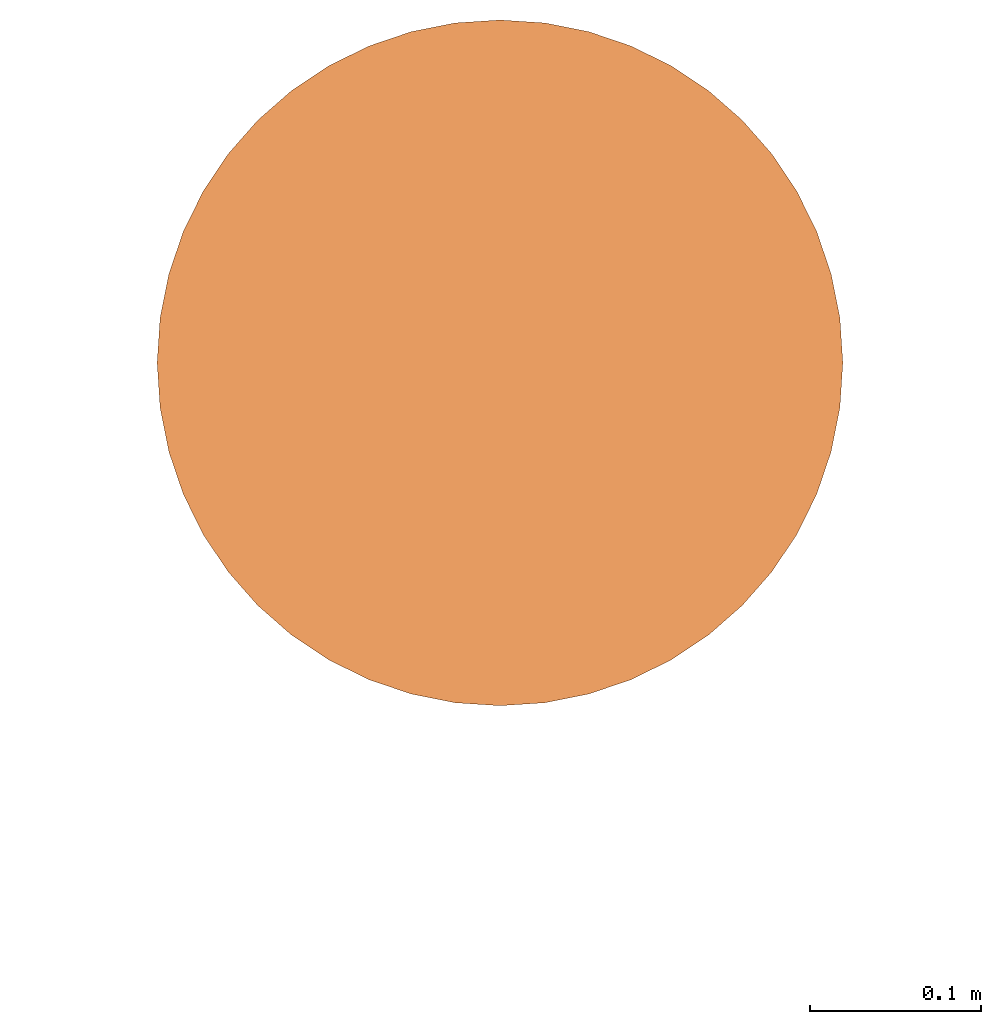
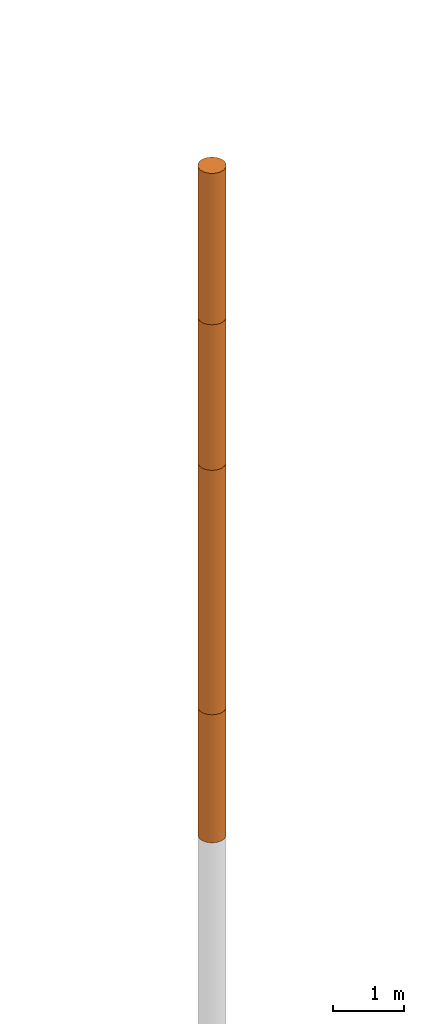
# Not in any storey, part 3 of 5: 4 geographic elements.
"""IFC4 model written with IfcOpenShell, lengths in metres."""

from ifc_helpers import new_model, entity, si_unit, converted_unit, frame, frame_2d, origin_with_axes, place, context, subcontext, project, spatial, polygons, element, save


model = new_model("IFC4")

# Units and contexts
model_context = context("Model", 3, precision=1e-05, world=origin_with_axes())
plan_context = context("Plan", 2, precision=1e-05, world=frame_2d((0.0, 0.0, 0.0), x_axis=(1.0, 0.0, 0.0)))
body_context = subcontext(model_context, "Body", "Model", "MODEL_VIEW")
ifc_project = project(units=[si_unit("VOLUMEUNIT", "CUBIC_METRE"), si_unit("LENGTHUNIT", "METRE"), converted_unit("PLANEANGLEUNIT", "degree", entity("IfcReal", 0.0174532925199433), si_unit("PLANEANGLEUNIT", "RADIAN"), dimensions=[0, 0, 0, 0, 0, 0, 0]), si_unit("AREAUNIT", "SQUARE_METRE")], contexts=[model_context, plan_context])

# Site
site_placement = place(None, origin_with_axes())
site = spatial("IfcSite", under=ifc_project, at=site_placement)

# Geographic elements
geographic_element_1_placement = place(site_placement, frame((19.3999996185303, 90.9000015258789, 17.6000003814697), z_axis=(0.0, 0.0, 1.0), x_axis=(1.0, 0.0, 0.0)))
element("IfcGeographicElement", 1, at=geographic_element_1_placement, inside=site, Name="BH_1_L_1", PredefinedType="NOTDEFINED", context=body_context, shape_type="Tessellation", body=[
    polygons([(0.0, 0.200000002980232, -1.29999995231628), (0.0, 0.200000002980232, 1.29999995231628), (0.0261052399873734, 0.198288977146149, -1.29999995231628), (0.0261052399873734, 0.198288977146149, 1.29999995231628), (0.0517638102173805, 0.193185165524483, -1.29999995231628), (0.0517638102173805, 0.193185165524483, 1.29999995231628), (0.0765366926789284, 0.184775903820992, -1.29999995231628), (0.0765366926789284, 0.184775903820992, 1.29999995231628), (0.100000001490116, 0.173205077648163, -1.29999995231628), (0.100000001490116, 0.173205077648163, 1.29999995231628), (0.12175228446722, 0.158670663833618, -1.29999995231628), (0.12175228446722, 0.158670663833618, 1.29999995231628), (0.141421362757683, 0.141421362757683, -1.29999995231628), (0.141421362757683, 0.141421362757683, 1.29999995231628), (0.158670663833618, 0.12175228446722, -1.29999995231628), (0.158670663833618, 0.12175228446722, 1.29999995231628), (0.173205077648163, 0.100000001490116, -1.29999995231628), (0.173205077648163, 0.100000001490116, 1.29999995231628), (0.184775903820992, 0.0765366926789284, -1.29999995231628), (0.184775903820992, 0.0765366926789284, 1.29999995231628), (0.193185165524483, 0.0517638102173805, -1.29999995231628), (0.193185165524483, 0.0517638102173805, 1.29999995231628), (0.198288977146149, 0.0261052399873734, -1.29999995231628), (0.198288977146149, 0.0261052399873734, 1.29999995231628), (0.200000002980232, 0.0, -1.29999995231628), (0.200000002980232, 0.0, 1.29999995231628), (0.198288977146149, -0.0261052399873734, -1.29999995231628), (0.198288977146149, -0.0261052399873734, 1.29999995231628), (0.193185165524483, -0.0517638102173805, -1.29999995231628), (0.193185165524483, -0.0517638102173805, 1.29999995231628), (0.184775903820992, -0.0765366926789284, -1.29999995231628), (0.184775903820992, -0.0765366926789284, 1.29999995231628), (0.173205077648163, -0.100000001490116, -1.29999995231628), (0.173205077648163, -0.100000001490116, 1.29999995231628), (0.158670663833618, -0.12175228446722, -1.29999995231628), (0.158670663833618, -0.12175228446722, 1.29999995231628), (0.141421362757683, -0.141421362757683, -1.29999995231628), (0.141421362757683, -0.141421362757683, 1.29999995231628), (0.12175228446722, -0.158670663833618, -1.29999995231628), (0.12175228446722, -0.158670663833618, 1.29999995231628), (0.100000001490116, -0.173205077648163, -1.29999995231628), (0.100000001490116, -0.173205077648163, 1.29999995231628), (0.0765366926789284, -0.184775903820992, -1.29999995231628), (0.0765366926789284, -0.184775903820992, 1.29999995231628), (0.0517638102173805, -0.193185165524483, -1.29999995231628), (0.0517638102173805, -0.193185165524483, 1.29999995231628), (0.0261052399873734, -0.198288977146149, -1.29999995231628), (0.0261052399873734, -0.198288977146149, 1.29999995231628), (0.0, -0.200000002980232, -1.29999995231628), (0.0, -0.200000002980232, 1.29999995231628), (-0.0261052399873734, -0.198288977146149, -1.29999995231628), (-0.0261052399873734, -0.198288977146149, 1.29999995231628), (-0.0517638102173805, -0.193185165524483, -1.29999995231628), (-0.0517638102173805, -0.193185165524483, 1.29999995231628), (-0.0765366926789284, -0.184775903820992, -1.29999995231628), (-0.0765366926789284, -0.184775903820992, 1.29999995231628), (-0.100000001490116, -0.173205077648163, -1.29999995231628), (-0.100000001490116, -0.173205077648163, 1.29999995231628), (-0.12175228446722, -0.158670663833618, -1.29999995231628), (-0.12175228446722, -0.158670663833618, 1.29999995231628), (-0.141421362757683, -0.141421362757683, -1.29999995231628), (-0.141421362757683, -0.141421362757683, 1.29999995231628), (-0.158670663833618, -0.12175228446722, -1.29999995231628), (-0.158670663833618, -0.12175228446722, 1.29999995231628), (-0.173205077648163, -0.100000001490116, -1.29999995231628), (-0.173205077648163, -0.100000001490116, 1.29999995231628), (-0.184775903820992, -0.0765366926789284, -1.29999995231628), (-0.184775903820992, -0.0765366926789284, 1.29999995231628), (-0.193185165524483, -0.0517638102173805, -1.29999995231628), (-0.193185165524483, -0.0517638102173805, 1.29999995231628), (-0.198288977146149, -0.0261052399873734, -1.29999995231628), (-0.198288977146149, -0.0261052399873734, 1.29999995231628), (-0.200000002980232, 0.0, -1.29999995231628), (-0.200000002980232, 0.0, 1.29999995231628), (-0.198288977146149, 0.0261052399873734, -1.29999995231628), (-0.198288977146149, 0.0261052399873734, 1.29999995231628), (-0.193185165524483, 0.0517638102173805, -1.29999995231628), (-0.193185165524483, 0.0517638102173805, 1.29999995231628), (-0.184775903820992, 0.0765366926789284, -1.29999995231628), (-0.184775903820992, 0.0765366926789284, 1.29999995231628), (-0.173205077648163, 0.100000001490116, -1.29999995231628), (-0.173205077648163, 0.100000001490116, 1.29999995231628), (-0.158670663833618, 0.12175228446722, -1.29999995231628), (-0.158670663833618, 0.12175228446722, 1.29999995231628), (-0.141421362757683, 0.141421362757683, -1.29999995231628), (-0.141421362757683, 0.141421362757683, 1.29999995231628), (-0.12175228446722, 0.158670663833618, -1.29999995231628), (-0.12175228446722, 0.158670663833618, 1.29999995231628), (-0.100000001490116, 0.173205077648163, -1.29999995231628), (-0.100000001490116, 0.173205077648163, 1.29999995231628), (-0.0765366926789284, 0.184775903820992, -1.29999995231628), (-0.0765366926789284, 0.184775903820992, 1.29999995231628), (-0.0517638102173805, 0.193185165524483, -1.29999995231628), (-0.0517638102173805, 0.193185165524483, 1.29999995231628), (-0.0261052399873734, 0.198288977146149, -1.29999995231628), (-0.0261052399873734, 0.198288977146149, 1.29999995231628)], [[[1, 2, 4, 3]], [[3, 4, 6, 5]], [[5, 6, 8, 7]], [[7, 8, 10, 9]], [[9, 10, 12, 11]], [[11, 12, 14, 13]], [[13, 14, 16, 15]], [[15, 16, 18, 17]], [[17, 18, 20, 19]], [[19, 20, 22, 21]], [[21, 22, 24, 23]], [[23, 24, 26, 25]], [[25, 26, 28, 27]], [[27, 28, 30, 29]], [[29, 30, 32, 31]], [[31, 32, 34, 33]], [[33, 34, 36, 35]], [[35, 36, 38, 37]], [[37, 38, 40, 39]], [[39, 40, 42, 41]], [[41, 42, 44, 43]], [[43, 44, 46, 45]], [[45, 46, 48, 47]], [[47, 48, 50, 49]], [[49, 50, 52, 51]], [[51, 52, 54, 53]], [[53, 54, 56, 55]], [[55, 56, 58, 57]], [[57, 58, 60, 59]], [[59, 60, 62, 61]], [[61, 62, 64, 63]], [[63, 64, 66, 65]], [[65, 66, 68, 67]], [[67, 68, 70, 69]], [[69, 70, 72, 71]], [[71, 72, 74, 73]], [[73, 74, 76, 75]], [[75, 76, 78, 77]], [[77, 78, 80, 79]], [[79, 80, 82, 81]], [[81, 82, 84, 83]], [[83, 84, 86, 85]], [[85, 86, 88, 87]], [[87, 88, 90, 89]], [[89, 90, 92, 91]], [[91, 92, 94, 93]], [[4, 2, 96, 94, 92, 90, 88, 86, 84, 82, 80, 78, 76, 74, 72, 70, 68, 66, 64, 62, 60, 58, 56, 54, 52, 50, 48, 46, 44, 42, 40, 38, 36, 34, 32, 30, 28, 26, 24, 22, 20, 18, 16, 14, 12, 10, 8, 6]], [[93, 94, 96, 95]], [[95, 96, 2, 1]], [[1, 3, 5, 7, 9, 11, 13, 15, 17, 19, 21, 23, 25, 27, 29, 31, 33, 35, 37, 39, 41, 43, 45, 47, 49, 51, 53, 55, 57, 59, 61, 63, 65, 67, 69, 71, 73, 75, 77, 79, 81, 83, 85, 87, 89, 91, 93, 95]]]),
])
geographic_element_2_placement = place(site_placement, frame((19.3999996185303, 90.9000015258789, 15.0500011444092), z_axis=(0.0, 0.0, 1.0), x_axis=(1.0, 0.0, 0.0)))
element("IfcGeographicElement", 2, at=geographic_element_2_placement, inside=site, Name="BH_1_L_2", PredefinedType="NOTDEFINED", context=body_context, shape_type="Tessellation", body=[
    polygons([(0.0, 0.200000002980232, -1.25), (0.0, 0.200000002980232, 1.25), (0.0261052399873734, 0.198288977146149, -1.25), (0.0261052399873734, 0.198288977146149, 1.25), (0.0517638102173805, 0.193185165524483, -1.25), (0.0517638102173805, 0.193185165524483, 1.25), (0.0765366926789284, 0.184775903820992, -1.25), (0.0765366926789284, 0.184775903820992, 1.25), (0.100000001490116, 0.173205077648163, -1.25), (0.100000001490116, 0.173205077648163, 1.25), (0.12175228446722, 0.158670663833618, -1.25), (0.12175228446722, 0.158670663833618, 1.25), (0.141421362757683, 0.141421362757683, -1.25), (0.141421362757683, 0.141421362757683, 1.25), (0.158670663833618, 0.12175228446722, -1.25), (0.158670663833618, 0.12175228446722, 1.25), (0.173205077648163, 0.100000001490116, -1.25), (0.173205077648163, 0.100000001490116, 1.25), (0.184775903820992, 0.0765366926789284, -1.25), (0.184775903820992, 0.0765366926789284, 1.25), (0.193185165524483, 0.0517638102173805, -1.25), (0.193185165524483, 0.0517638102173805, 1.25), (0.198288977146149, 0.0261052399873734, -1.25), (0.198288977146149, 0.0261052399873734, 1.25), (0.200000002980232, 0.0, -1.25), (0.200000002980232, 0.0, 1.25), (0.198288977146149, -0.0261052399873734, -1.25), (0.198288977146149, -0.0261052399873734, 1.25), (0.193185165524483, -0.0517638102173805, -1.25), (0.193185165524483, -0.0517638102173805, 1.25), (0.184775903820992, -0.0765366926789284, -1.25), (0.184775903820992, -0.0765366926789284, 1.25), (0.173205077648163, -0.100000001490116, -1.25), (0.173205077648163, -0.100000001490116, 1.25), (0.158670663833618, -0.12175228446722, -1.25), (0.158670663833618, -0.12175228446722, 1.25), (0.141421362757683, -0.141421362757683, -1.25), (0.141421362757683, -0.141421362757683, 1.25), (0.12175228446722, -0.158670663833618, -1.25), (0.12175228446722, -0.158670663833618, 1.25), (0.100000001490116, -0.173205077648163, -1.25), (0.100000001490116, -0.173205077648163, 1.25), (0.0765366926789284, -0.184775903820992, -1.25), (0.0765366926789284, -0.184775903820992, 1.25), (0.0517638102173805, -0.193185165524483, -1.25), (0.0517638102173805, -0.193185165524483, 1.25), (0.0261052399873734, -0.198288977146149, -1.25), (0.0261052399873734, -0.198288977146149, 1.25), (0.0, -0.200000002980232, -1.25), (0.0, -0.200000002980232, 1.25), (-0.0261052399873734, -0.198288977146149, -1.25), (-0.0261052399873734, -0.198288977146149, 1.25), (-0.0517638102173805, -0.193185165524483, -1.25), (-0.0517638102173805, -0.193185165524483, 1.25), (-0.0765366926789284, -0.184775903820992, -1.25), (-0.0765366926789284, -0.184775903820992, 1.25), (-0.100000001490116, -0.173205077648163, -1.25), (-0.100000001490116, -0.173205077648163, 1.25), (-0.12175228446722, -0.158670663833618, -1.25), (-0.12175228446722, -0.158670663833618, 1.25), (-0.141421362757683, -0.141421362757683, -1.25), (-0.141421362757683, -0.141421362757683, 1.25), (-0.158670663833618, -0.12175228446722, -1.25), (-0.158670663833618, -0.12175228446722, 1.25), (-0.173205077648163, -0.100000001490116, -1.25), (-0.173205077648163, -0.100000001490116, 1.25), (-0.184775903820992, -0.0765366926789284, -1.25), (-0.184775903820992, -0.0765366926789284, 1.25), (-0.193185165524483, -0.0517638102173805, -1.25), (-0.193185165524483, -0.0517638102173805, 1.25), (-0.198288977146149, -0.0261052399873734, -1.25), (-0.198288977146149, -0.0261052399873734, 1.25), (-0.200000002980232, 0.0, -1.25), (-0.200000002980232, 0.0, 1.25), (-0.198288977146149, 0.0261052399873734, -1.25), (-0.198288977146149, 0.0261052399873734, 1.25), (-0.193185165524483, 0.0517638102173805, -1.25), (-0.193185165524483, 0.0517638102173805, 1.25), (-0.184775903820992, 0.0765366926789284, -1.25), (-0.184775903820992, 0.0765366926789284, 1.25), (-0.173205077648163, 0.100000001490116, -1.25), (-0.173205077648163, 0.100000001490116, 1.25), (-0.158670663833618, 0.12175228446722, -1.25), (-0.158670663833618, 0.12175228446722, 1.25), (-0.141421362757683, 0.141421362757683, -1.25), (-0.141421362757683, 0.141421362757683, 1.25), (-0.12175228446722, 0.158670663833618, -1.25), (-0.12175228446722, 0.158670663833618, 1.25), (-0.100000001490116, 0.173205077648163, -1.25), (-0.100000001490116, 0.173205077648163, 1.25), (-0.0765366926789284, 0.184775903820992, -1.25), (-0.0765366926789284, 0.184775903820992, 1.25), (-0.0517638102173805, 0.193185165524483, -1.25), (-0.0517638102173805, 0.193185165524483, 1.25), (-0.0261052399873734, 0.198288977146149, -1.25), (-0.0261052399873734, 0.198288977146149, 1.25)], [[[1, 2, 4, 3]], [[3, 4, 6, 5]], [[5, 6, 8, 7]], [[7, 8, 10, 9]], [[9, 10, 12, 11]], [[11, 12, 14, 13]], [[13, 14, 16, 15]], [[15, 16, 18, 17]], [[17, 18, 20, 19]], [[19, 20, 22, 21]], [[21, 22, 24, 23]], [[23, 24, 26, 25]], [[25, 26, 28, 27]], [[27, 28, 30, 29]], [[29, 30, 32, 31]], [[31, 32, 34, 33]], [[33, 34, 36, 35]], [[35, 36, 38, 37]], [[37, 38, 40, 39]], [[39, 40, 42, 41]], [[41, 42, 44, 43]], [[43, 44, 46, 45]], [[45, 46, 48, 47]], [[47, 48, 50, 49]], [[49, 50, 52, 51]], [[51, 52, 54, 53]], [[53, 54, 56, 55]], [[55, 56, 58, 57]], [[57, 58, 60, 59]], [[59, 60, 62, 61]], [[61, 62, 64, 63]], [[63, 64, 66, 65]], [[65, 66, 68, 67]], [[67, 68, 70, 69]], [[69, 70, 72, 71]], [[71, 72, 74, 73]], [[73, 74, 76, 75]], [[75, 76, 78, 77]], [[77, 78, 80, 79]], [[79, 80, 82, 81]], [[81, 82, 84, 83]], [[83, 84, 86, 85]], [[85, 86, 88, 87]], [[87, 88, 90, 89]], [[89, 90, 92, 91]], [[91, 92, 94, 93]], [[4, 2, 96, 94, 92, 90, 88, 86, 84, 82, 80, 78, 76, 74, 72, 70, 68, 66, 64, 62, 60, 58, 56, 54, 52, 50, 48, 46, 44, 42, 40, 38, 36, 34, 32, 30, 28, 26, 24, 22, 20, 18, 16, 14, 12, 10, 8, 6]], [[93, 94, 96, 95]], [[95, 96, 2, 1]], [[1, 3, 5, 7, 9, 11, 13, 15, 17, 19, 21, 23, 25, 27, 29, 31, 33, 35, 37, 39, 41, 43, 45, 47, 49, 51, 53, 55, 57, 59, 61, 63, 65, 67, 69, 71, 73, 75, 77, 79, 81, 83, 85, 87, 89, 91, 93, 95]]]),
])
geographic_element_3_placement = place(site_placement, frame((19.3999996185303, 90.9000015258789, 11.7000017166138), z_axis=(0.0, 0.0, 1.0), x_axis=(1.0, 0.0, 0.0)))
element("IfcGeographicElement", 3, at=geographic_element_3_placement, inside=site, PredefinedType="NOTDEFINED", context=body_context, shape_type="Tessellation", body=[
    polygons([(0.0, 0.200000002980232, -2.09999990463257), (0.0, 0.200000002980232, 2.09999990463257), (0.0261052399873734, 0.198288977146149, -2.09999990463257), (0.0261052399873734, 0.198288977146149, 2.09999990463257), (0.0517638102173805, 0.193185165524483, -2.09999990463257), (0.0517638102173805, 0.193185165524483, 2.09999990463257), (0.0765366926789284, 0.184775903820992, -2.09999990463257), (0.0765366926789284, 0.184775903820992, 2.09999990463257), (0.100000001490116, 0.173205077648163, -2.09999990463257), (0.100000001490116, 0.173205077648163, 2.09999990463257), (0.12175228446722, 0.158670663833618, -2.09999990463257), (0.12175228446722, 0.158670663833618, 2.09999990463257), (0.141421362757683, 0.141421362757683, -2.09999990463257), (0.141421362757683, 0.141421362757683, 2.09999990463257), (0.158670663833618, 0.12175228446722, -2.09999990463257), (0.158670663833618, 0.12175228446722, 2.09999990463257), (0.173205077648163, 0.100000001490116, -2.09999990463257), (0.173205077648163, 0.100000001490116, 2.09999990463257), (0.184775903820992, 0.0765366926789284, -2.09999990463257), (0.184775903820992, 0.0765366926789284, 2.09999990463257), (0.193185165524483, 0.0517638102173805, -2.09999990463257), (0.193185165524483, 0.0517638102173805, 2.09999990463257), (0.198288977146149, 0.0261052399873734, -2.09999990463257), (0.198288977146149, 0.0261052399873734, 2.09999990463257), (0.200000002980232, 0.0, -2.09999990463257), (0.200000002980232, 0.0, 2.09999990463257), (0.198288977146149, -0.0261052399873734, -2.09999990463257), (0.198288977146149, -0.0261052399873734, 2.09999990463257), (0.193185165524483, -0.0517638102173805, -2.09999990463257), (0.193185165524483, -0.0517638102173805, 2.09999990463257), (0.184775903820992, -0.0765366926789284, -2.09999990463257), (0.184775903820992, -0.0765366926789284, 2.09999990463257), (0.173205077648163, -0.100000001490116, -2.09999990463257), (0.173205077648163, -0.100000001490116, 2.09999990463257), (0.158670663833618, -0.12175228446722, -2.09999990463257), (0.158670663833618, -0.12175228446722, 2.09999990463257), (0.141421362757683, -0.141421362757683, -2.09999990463257), (0.141421362757683, -0.141421362757683, 2.09999990463257), (0.12175228446722, -0.158670663833618, -2.09999990463257), (0.12175228446722, -0.158670663833618, 2.09999990463257), (0.100000001490116, -0.173205077648163, -2.09999990463257), (0.100000001490116, -0.173205077648163, 2.09999990463257), (0.0765366926789284, -0.184775903820992, -2.09999990463257), (0.0765366926789284, -0.184775903820992, 2.09999990463257), (0.0517638102173805, -0.193185165524483, -2.09999990463257), (0.0517638102173805, -0.193185165524483, 2.09999990463257), (0.0261052399873734, -0.198288977146149, -2.09999990463257), (0.0261052399873734, -0.198288977146149, 2.09999990463257), (0.0, -0.200000002980232, -2.09999990463257), (0.0, -0.200000002980232, 2.09999990463257), (-0.0261052399873734, -0.198288977146149, -2.09999990463257), (-0.0261052399873734, -0.198288977146149, 2.09999990463257), (-0.0517638102173805, -0.193185165524483, -2.09999990463257), (-0.0517638102173805, -0.193185165524483, 2.09999990463257), (-0.0765366926789284, -0.184775903820992, -2.09999990463257), (-0.0765366926789284, -0.184775903820992, 2.09999990463257), (-0.100000001490116, -0.173205077648163, -2.09999990463257), (-0.100000001490116, -0.173205077648163, 2.09999990463257), (-0.12175228446722, -0.158670663833618, -2.09999990463257), (-0.12175228446722, -0.158670663833618, 2.09999990463257), (-0.141421362757683, -0.141421362757683, -2.09999990463257), (-0.141421362757683, -0.141421362757683, 2.09999990463257), (-0.158670663833618, -0.12175228446722, -2.09999990463257), (-0.158670663833618, -0.12175228446722, 2.09999990463257), (-0.173205077648163, -0.100000001490116, -2.09999990463257), (-0.173205077648163, -0.100000001490116, 2.09999990463257), (-0.184775903820992, -0.0765366926789284, -2.09999990463257), (-0.184775903820992, -0.0765366926789284, 2.09999990463257), (-0.193185165524483, -0.0517638102173805, -2.09999990463257), (-0.193185165524483, -0.0517638102173805, 2.09999990463257), (-0.198288977146149, -0.0261052399873734, -2.09999990463257), (-0.198288977146149, -0.0261052399873734, 2.09999990463257), (-0.200000002980232, 0.0, -2.09999990463257), (-0.200000002980232, 0.0, 2.09999990463257), (-0.198288977146149, 0.0261052399873734, -2.09999990463257), (-0.198288977146149, 0.0261052399873734, 2.09999990463257), (-0.193185165524483, 0.0517638102173805, -2.09999990463257), (-0.193185165524483, 0.0517638102173805, 2.09999990463257), (-0.184775903820992, 0.0765366926789284, -2.09999990463257), (-0.184775903820992, 0.0765366926789284, 2.09999990463257), (-0.173205077648163, 0.100000001490116, -2.09999990463257), (-0.173205077648163, 0.100000001490116, 2.09999990463257), (-0.158670663833618, 0.12175228446722, -2.09999990463257), (-0.158670663833618, 0.12175228446722, 2.09999990463257), (-0.141421362757683, 0.141421362757683, -2.09999990463257), (-0.141421362757683, 0.141421362757683, 2.09999990463257), (-0.12175228446722, 0.158670663833618, -2.09999990463257), (-0.12175228446722, 0.158670663833618, 2.09999990463257), (-0.100000001490116, 0.173205077648163, -2.09999990463257), (-0.100000001490116, 0.173205077648163, 2.09999990463257), (-0.0765366926789284, 0.184775903820992, -2.09999990463257), (-0.0765366926789284, 0.184775903820992, 2.09999990463257), (-0.0517638102173805, 0.193185165524483, -2.09999990463257), (-0.0517638102173805, 0.193185165524483, 2.09999990463257), (-0.0261052399873734, 0.198288977146149, -2.09999990463257), (-0.0261052399873734, 0.198288977146149, 2.09999990463257)], [[[1, 2, 4, 3]], [[3, 4, 6, 5]], [[5, 6, 8, 7]], [[7, 8, 10, 9]], [[9, 10, 12, 11]], [[11, 12, 14, 13]], [[13, 14, 16, 15]], [[15, 16, 18, 17]], [[17, 18, 20, 19]], [[19, 20, 22, 21]], [[21, 22, 24, 23]], [[23, 24, 26, 25]], [[25, 26, 28, 27]], [[27, 28, 30, 29]], [[29, 30, 32, 31]], [[31, 32, 34, 33]], [[33, 34, 36, 35]], [[35, 36, 38, 37]], [[37, 38, 40, 39]], [[39, 40, 42, 41]], [[41, 42, 44, 43]], [[43, 44, 46, 45]], [[45, 46, 48, 47]], [[47, 48, 50, 49]], [[49, 50, 52, 51]], [[51, 52, 54, 53]], [[53, 54, 56, 55]], [[55, 56, 58, 57]], [[57, 58, 60, 59]], [[59, 60, 62, 61]], [[61, 62, 64, 63]], [[63, 64, 66, 65]], [[65, 66, 68, 67]], [[67, 68, 70, 69]], [[69, 70, 72, 71]], [[71, 72, 74, 73]], [[73, 74, 76, 75]], [[75, 76, 78, 77]], [[77, 78, 80, 79]], [[79, 80, 82, 81]], [[81, 82, 84, 83]], [[83, 84, 86, 85]], [[85, 86, 88, 87]], [[87, 88, 90, 89]], [[89, 90, 92, 91]], [[91, 92, 94, 93]], [[4, 2, 96, 94, 92, 90, 88, 86, 84, 82, 80, 78, 76, 74, 72, 70, 68, 66, 64, 62, 60, 58, 56, 54, 52, 50, 48, 46, 44, 42, 40, 38, 36, 34, 32, 30, 28, 26, 24, 22, 20, 18, 16, 14, 12, 10, 8, 6]], [[93, 94, 96, 95]], [[95, 96, 2, 1]], [[1, 3, 5, 7, 9, 11, 13, 15, 17, 19, 21, 23, 25, 27, 29, 31, 33, 35, 37, 39, 41, 43, 45, 47, 49, 51, 53, 55, 57, 59, 61, 63, 65, 67, 69, 71, 73, 75, 77, 79, 81, 83, 85, 87, 89, 91, 93, 95]]]),
])
geographic_element_4_placement = place(site_placement, frame((19.3999996185303, 90.9000015258789, 8.50000190734863), z_axis=(0.0, 0.0, 1.0), x_axis=(1.0, 0.0, 0.0)))
element("IfcGeographicElement", 4, at=geographic_element_4_placement, inside=site, Name="BH_1_L_3", PredefinedType="NOTDEFINED", context=body_context, shape_type="Tessellation", body=[
    polygons([(0.0, 0.200000002980232, -1.10000002384186), (0.0, 0.200000002980232, 1.10000002384186), (0.0261052399873734, 0.198288977146149, -1.10000002384186), (0.0261052399873734, 0.198288977146149, 1.10000002384186), (0.0517638102173805, 0.193185165524483, -1.10000002384186), (0.0517638102173805, 0.193185165524483, 1.10000002384186), (0.0765366926789284, 0.184775903820992, -1.10000002384186), (0.0765366926789284, 0.184775903820992, 1.10000002384186), (0.100000001490116, 0.173205077648163, -1.10000002384186), (0.100000001490116, 0.173205077648163, 1.10000002384186), (0.12175228446722, 0.158670663833618, -1.10000002384186), (0.12175228446722, 0.158670663833618, 1.10000002384186), (0.141421362757683, 0.141421362757683, -1.10000002384186), (0.141421362757683, 0.141421362757683, 1.10000002384186), (0.158670663833618, 0.12175228446722, -1.10000002384186), (0.158670663833618, 0.12175228446722, 1.10000002384186), (0.173205077648163, 0.100000001490116, -1.10000002384186), (0.173205077648163, 0.100000001490116, 1.10000002384186), (0.184775903820992, 0.0765366926789284, -1.10000002384186), (0.184775903820992, 0.0765366926789284, 1.10000002384186), (0.193185165524483, 0.0517638102173805, -1.10000002384186), (0.193185165524483, 0.0517638102173805, 1.10000002384186), (0.198288977146149, 0.0261052399873734, -1.10000002384186), (0.198288977146149, 0.0261052399873734, 1.10000002384186), (0.200000002980232, 0.0, -1.10000002384186), (0.200000002980232, 0.0, 1.10000002384186), (0.198288977146149, -0.0261052399873734, -1.10000002384186), (0.198288977146149, -0.0261052399873734, 1.10000002384186), (0.193185165524483, -0.0517638102173805, -1.10000002384186), (0.193185165524483, -0.0517638102173805, 1.10000002384186), (0.184775903820992, -0.0765366926789284, -1.10000002384186), (0.184775903820992, -0.0765366926789284, 1.10000002384186), (0.173205077648163, -0.100000001490116, -1.10000002384186), (0.173205077648163, -0.100000001490116, 1.10000002384186), (0.158670663833618, -0.12175228446722, -1.10000002384186), (0.158670663833618, -0.12175228446722, 1.10000002384186), (0.141421362757683, -0.141421362757683, -1.10000002384186), (0.141421362757683, -0.141421362757683, 1.10000002384186), (0.12175228446722, -0.158670663833618, -1.10000002384186), (0.12175228446722, -0.158670663833618, 1.10000002384186), (0.100000001490116, -0.173205077648163, -1.10000002384186), (0.100000001490116, -0.173205077648163, 1.10000002384186), (0.0765366926789284, -0.184775903820992, -1.10000002384186), (0.0765366926789284, -0.184775903820992, 1.10000002384186), (0.0517638102173805, -0.193185165524483, -1.10000002384186), (0.0517638102173805, -0.193185165524483, 1.10000002384186), (0.0261052399873734, -0.198288977146149, -1.10000002384186), (0.0261052399873734, -0.198288977146149, 1.10000002384186), (0.0, -0.200000002980232, -1.10000002384186), (0.0, -0.200000002980232, 1.10000002384186), (-0.0261052399873734, -0.198288977146149, -1.10000002384186), (-0.0261052399873734, -0.198288977146149, 1.10000002384186), (-0.0517638102173805, -0.193185165524483, -1.10000002384186), (-0.0517638102173805, -0.193185165524483, 1.10000002384186), (-0.0765366926789284, -0.184775903820992, -1.10000002384186), (-0.0765366926789284, -0.184775903820992, 1.10000002384186), (-0.100000001490116, -0.173205077648163, -1.10000002384186), (-0.100000001490116, -0.173205077648163, 1.10000002384186), (-0.12175228446722, -0.158670663833618, -1.10000002384186), (-0.12175228446722, -0.158670663833618, 1.10000002384186), (-0.141421362757683, -0.141421362757683, -1.10000002384186), (-0.141421362757683, -0.141421362757683, 1.10000002384186), (-0.158670663833618, -0.12175228446722, -1.10000002384186), (-0.158670663833618, -0.12175228446722, 1.10000002384186), (-0.173205077648163, -0.100000001490116, -1.10000002384186), (-0.173205077648163, -0.100000001490116, 1.10000002384186), (-0.184775903820992, -0.0765366926789284, -1.10000002384186), (-0.184775903820992, -0.0765366926789284, 1.10000002384186), (-0.193185165524483, -0.0517638102173805, -1.10000002384186), (-0.193185165524483, -0.0517638102173805, 1.10000002384186), (-0.198288977146149, -0.0261052399873734, -1.10000002384186), (-0.198288977146149, -0.0261052399873734, 1.10000002384186), (-0.200000002980232, 0.0, -1.10000002384186), (-0.200000002980232, 0.0, 1.10000002384186), (-0.198288977146149, 0.0261052399873734, -1.10000002384186), (-0.198288977146149, 0.0261052399873734, 1.10000002384186), (-0.193185165524483, 0.0517638102173805, -1.10000002384186), (-0.193185165524483, 0.0517638102173805, 1.10000002384186), (-0.184775903820992, 0.0765366926789284, -1.10000002384186), (-0.184775903820992, 0.0765366926789284, 1.10000002384186), (-0.173205077648163, 0.100000001490116, -1.10000002384186), (-0.173205077648163, 0.100000001490116, 1.10000002384186), (-0.158670663833618, 0.12175228446722, -1.10000002384186), (-0.158670663833618, 0.12175228446722, 1.10000002384186), (-0.141421362757683, 0.141421362757683, -1.10000002384186), (-0.141421362757683, 0.141421362757683, 1.10000002384186), (-0.12175228446722, 0.158670663833618, -1.10000002384186), (-0.12175228446722, 0.158670663833618, 1.10000002384186), (-0.100000001490116, 0.173205077648163, -1.10000002384186), (-0.100000001490116, 0.173205077648163, 1.10000002384186), (-0.0765366926789284, 0.184775903820992, -1.10000002384186), (-0.0765366926789284, 0.184775903820992, 1.10000002384186), (-0.0517638102173805, 0.193185165524483, -1.10000002384186), (-0.0517638102173805, 0.193185165524483, 1.10000002384186), (-0.0261052399873734, 0.198288977146149, -1.10000002384186), (-0.0261052399873734, 0.198288977146149, 1.10000002384186)], [[[1, 2, 4, 3]], [[3, 4, 6, 5]], [[5, 6, 8, 7]], [[7, 8, 10, 9]], [[9, 10, 12, 11]], [[11, 12, 14, 13]], [[13, 14, 16, 15]], [[15, 16, 18, 17]], [[17, 18, 20, 19]], [[19, 20, 22, 21]], [[21, 22, 24, 23]], [[23, 24, 26, 25]], [[25, 26, 28, 27]], [[27, 28, 30, 29]], [[29, 30, 32, 31]], [[31, 32, 34, 33]], [[33, 34, 36, 35]], [[35, 36, 38, 37]], [[37, 38, 40, 39]], [[39, 40, 42, 41]], [[41, 42, 44, 43]], [[43, 44, 46, 45]], [[45, 46, 48, 47]], [[47, 48, 50, 49]], [[49, 50, 52, 51]], [[51, 52, 54, 53]], [[53, 54, 56, 55]], [[55, 56, 58, 57]], [[57, 58, 60, 59]], [[59, 60, 62, 61]], [[61, 62, 64, 63]], [[63, 64, 66, 65]], [[65, 66, 68, 67]], [[67, 68, 70, 69]], [[69, 70, 72, 71]], [[71, 72, 74, 73]], [[73, 74, 76, 75]], [[75, 76, 78, 77]], [[77, 78, 80, 79]], [[79, 80, 82, 81]], [[81, 82, 84, 83]], [[83, 84, 86, 85]], [[85, 86, 88, 87]], [[87, 88, 90, 89]], [[89, 90, 92, 91]], [[91, 92, 94, 93]], [[4, 2, 96, 94, 92, 90, 88, 86, 84, 82, 80, 78, 76, 74, 72, 70, 68, 66, 64, 62, 60, 58, 56, 54, 52, 50, 48, 46, 44, 42, 40, 38, 36, 34, 32, 30, 28, 26, 24, 22, 20, 18, 16, 14, 12, 10, 8, 6]], [[93, 94, 96, 95]], [[95, 96, 2, 1]], [[1, 3, 5, 7, 9, 11, 13, 15, 17, 19, 21, 23, 25, 27, 29, 31, 33, 35, 37, 39, 41, 43, 45, 47, 49, 51, 53, 55, 57, 59, 61, 63, 65, 67, 69, 71, 73, 75, 77, 79, 81, 83, 85, 87, 89, 91, 93, 95]]]),
])

save(model, "model.ifc")
